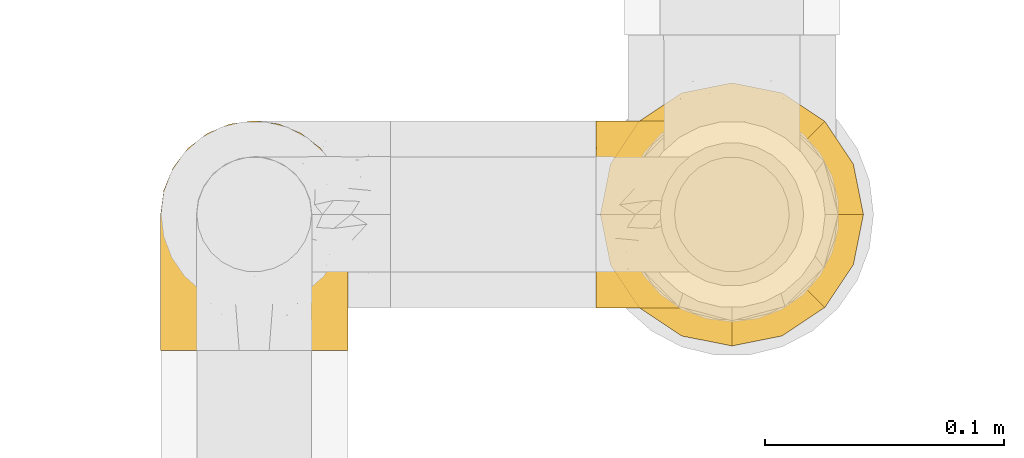
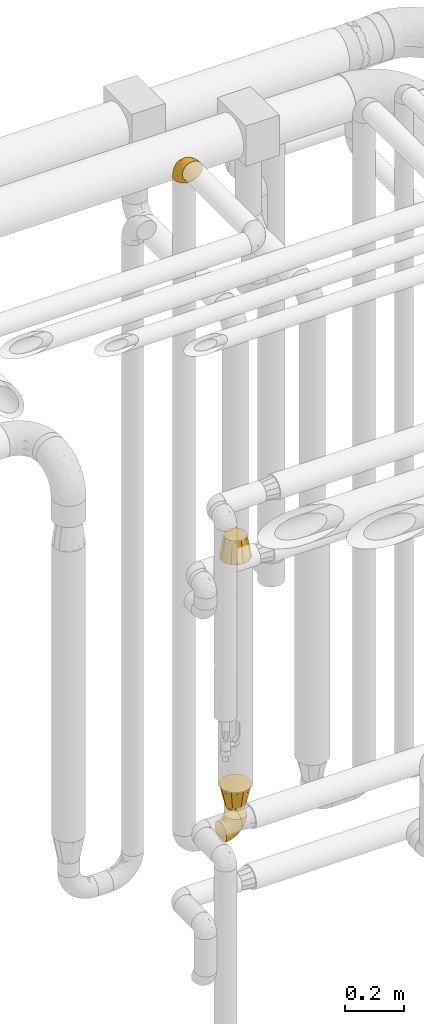
# One storey, part 481 of 827: 4 coverings.
"""IFC2X3 building model written with IfcOpenShell, lengths in millimetres."""

from ifc_helpers import new_model, entity, si_unit, converted_unit, derived_unit, direction, frame, origin, place, context, subcontext, project, spatial, faceted_brep, element, save


model = new_model("IFC2X3")

# Units and contexts
model_context = context("Model", 3, precision=0.01, world=origin(), true_north=direction((6.12303176911189e-17, 1.0)))
body_context = subcontext(model_context, "Body", "Model", "MODEL_VIEW")
ifc_project = project(units=[si_unit("LENGTHUNIT", "METRE", prefix="MILLI"), si_unit("AREAUNIT", "SQUARE_METRE"), si_unit("VOLUMEUNIT", "CUBIC_METRE"), converted_unit("PLANEANGLEUNIT", "DEGREE", entity("IfcRatioMeasure", 0.0174532925199433), si_unit("PLANEANGLEUNIT", "RADIAN"), dimensions=[0, 0, 0, 0, 0, 0, 0]), si_unit("MASSUNIT", "GRAM", prefix="KILO"), derived_unit("MASSDENSITYUNIT", [(si_unit("MASSUNIT", "GRAM", prefix="KILO"), 1), (si_unit("LENGTHUNIT", "METRE"), -3)]), derived_unit("MOMENTOFINERTIAUNIT", [(si_unit("LENGTHUNIT", "METRE"), 4)]), si_unit("TIMEUNIT", "SECOND"), si_unit("FREQUENCYUNIT", "HERTZ"), si_unit("THERMODYNAMICTEMPERATUREUNIT", "DEGREE_CELSIUS"), derived_unit("THERMALTRANSMITTANCEUNIT", [(si_unit("MASSUNIT", "GRAM", prefix="KILO"), 1), (si_unit("THERMODYNAMICTEMPERATUREUNIT", "KELVIN"), -1), (si_unit("TIMEUNIT", "SECOND"), -3)]), derived_unit("VOLUMETRICFLOWRATEUNIT", [(si_unit("LENGTHUNIT", "METRE"), 3), (si_unit("TIMEUNIT", "SECOND"), -1)]), derived_unit("MASSFLOWRATEUNIT", [(si_unit("MASSUNIT", "GRAM", prefix="KILO"), 1), (si_unit("TIMEUNIT", "SECOND"), -1)]), derived_unit("ROTATIONALFREQUENCYUNIT", [(si_unit("TIMEUNIT", "SECOND"), -1)]), si_unit("ELECTRICCURRENTUNIT", "AMPERE"), si_unit("ELECTRICVOLTAGEUNIT", "VOLT"), si_unit("POWERUNIT", "WATT"), si_unit("FORCEUNIT", "NEWTON", prefix="KILO"), si_unit("ILLUMINANCEUNIT", "LUX"), si_unit("LUMINOUSFLUXUNIT", "LUMEN"), si_unit("LUMINOUSINTENSITYUNIT", "CANDELA"), derived_unit("USERDEFINED", [(si_unit("MASSUNIT", "GRAM", prefix="KILO"), -1), (si_unit("LENGTHUNIT", "METRE"), -2), (si_unit("TIMEUNIT", "SECOND"), 3), (si_unit("LUMINOUSFLUXUNIT", "LUMEN"), 1)]), derived_unit("LINEARVELOCITYUNIT", [(si_unit("LENGTHUNIT", "METRE"), 1), (si_unit("TIMEUNIT", "SECOND"), -1)]), si_unit("PRESSUREUNIT", "PASCAL"), derived_unit("USERDEFINED", [(si_unit("LENGTHUNIT", "METRE"), -2), (si_unit("MASSUNIT", "GRAM", prefix="KILO"), 1), (si_unit("TIMEUNIT", "SECOND"), -2)]), derived_unit("LINEARFORCEUNIT", [(si_unit("MASSUNIT", "GRAM", prefix="KILO"), 1), (si_unit("LENGTHUNIT", "METRE"), 1), (si_unit("TIMEUNIT", "SECOND"), -2), (si_unit("LENGTHUNIT", "METRE"), -1)]), derived_unit("PLANARFORCEUNIT", [(si_unit("MASSUNIT", "GRAM", prefix="KILO"), 1), (si_unit("LENGTHUNIT", "METRE"), 1), (si_unit("TIMEUNIT", "SECOND"), -2), (si_unit("LENGTHUNIT", "METRE"), -2)])], contexts=[model_context])

# Site, building, storey
site_placement = place(None, origin())
site = spatial("IfcSite", under=ifc_project, at=site_placement, CompositionType="ELEMENT")
building_placement = place(site_placement, origin())
building = spatial("IfcBuilding", under=site, at=building_placement, CompositionType="ELEMENT")
storey_placement = place(building_placement, frame((0.0, 0.0, 28200.0)))
storey = spatial("IfcBuildingStorey", under=building, at=storey_placement, Name="08", CompositionType="ELEMENT", Elevation=28200.0)

# Coverings
covering_1_placement = place(storey_placement, frame((59239.54, 17459.25, 359.25)))
element("IfcCovering", 1, at=covering_1_placement, inside=storey, Name=":ADSK_", ObjectType=":ADSK_", PredefinedType="INSULATION", context=body_context, shape_type="Brep", body=[
    faceted_brep([(58.6, 1.6, 97.75), (67.31, 2.58, 97.75), (75.59, 5.48, 97.75), (83.01, 10.14, 97.75), (89.21, 16.34, 97.75), (93.87, 23.76, 97.75), (96.76, 32.04, 97.75), (97.75, 40.75, 97.75), (96.76, 49.46, 97.75), (93.87, 57.74, 97.75), (89.2, 65.16, 97.75), (83.0, 71.36, 97.75), (75.58, 76.02, 97.75), (67.3, 78.91, 97.75), (58.6, 79.9, 97.75), (55.4, 79.53, 97.75), (49.88, 78.91, 97.75), (45.74, 77.46, 97.75), (41.6, 76.02, 97.75), (34.18, 71.35, 97.75), (27.98, 65.15, 97.75), (23.32, 57.73, 97.75), (20.43, 49.45, 97.75), (19.45, 40.75, 97.75), (20.43, 32.03, 97.75), (23.33, 23.75, 97.75), (27.99, 16.33, 97.75), (34.19, 10.13, 97.75), (41.61, 5.47, 97.75), (49.89, 2.58, 97.75), (55.4, 1.96, 97.75), (1.6, 68.43, 68.43), (1.6, 74.65, 60.32), (1.6, 78.56, 50.88), (1.6, 79.05, 47.16), (1.6, 79.47, 43.95), (1.6, 79.9, 40.75), (1.6, 78.56, 30.61), (1.6, 74.65, 21.17), (1.6, 68.43, 13.06), (1.6, 60.32, 6.84), (1.6, 50.88, 2.93), (1.6, 40.75, 1.6), (1.6, 30.61, 2.93), (1.6, 21.17, 6.84), (1.6, 13.06, 13.06), (1.6, 6.84, 21.17), (1.6, 2.93, 30.61), (1.6, 1.6, 40.75), (1.6, 2.44, 47.16), (1.6, 2.93, 50.88), (1.6, 6.84, 60.32), (1.6, 13.06, 68.43), (1.6, 21.17, 74.65), (1.6, 30.61, 78.56), (1.6, 40.75, 79.9), (1.6, 50.88, 78.56), (1.6, 60.32, 74.65), (68.75, 40.75, 30.59), (79.38, 40.75, 41.23), (67.95, 27.5, 31.39), (58.11, 40.75, 19.96), (31.31, 40.75, 6.3), (25.48, 34.0, 5.21), (20.85, 40.75, 4.64), (48.28, 29.97, 15.42), (38.29, 19.63, 15.6), (24.38, 27.06, 6.88), (18.7, 18.12, 10.45), (63.4, 2.24, 80.79), (43.9, 4.45, 39.87), (21.15, 5.7, 25.91), (41.26, 8.88, 28.57), (20.94, 2.56, 35.0), (24.69, 11.37, 18.15), (84.73, 14.79, 74.57), (79.29, 8.79, 80.38), (75.09, 11.28, 59.65), (55.53, 2.69, 59.36), (54.26, 1.6, 75.93), (51.17, 1.6, 71.31), (48.08, 1.6, 66.69), (44.99, 1.6, 62.06), (41.9, 1.6, 57.44), (59.1, 7.05, 46.63), (93.12, 29.02, 74.83), (38.11, 2.16, 45.67), (37.28, 1.6, 54.35), (32.65, 1.6, 51.26), (28.03, 1.6, 48.17), (23.41, 1.6, 45.08), (86.26, 32.55, 54.03), (84.36, 22.71, 58.15), (90.84, 21.06, 80.8), (94.7, 40.75, 78.49), (62.67, 19.47, 31.82), (76.37, 23.96, 43.52), (57.88, 1.6, 94.17), (57.17, 1.6, 90.6), (55.75, 1.6, 83.46), (74.1, 17.37, 47.16), (68.09, 5.73, 64.11), (72.38, 4.85, 81.54), (61.34, 12.58, 38.43), (48.69, 14.76, 25.45), (44.71, 40.75, 13.13), (93.04, 40.75, 68.03), (15.88, 1.6, 43.59), (12.31, 1.6, 42.88), (8.74, 1.6, 42.17), (86.21, 40.75, 54.63), (7.55, 17.63, 73.05), (12.14, 12.34, 69.6), (11.84, 2.84, 51.66), (9.55, 8.51, 63.89), (10.89, 5.02, 57.82), (17.57, 4.67, 59.13), (19.53, 2.44, 52.25), (25.5, 2.4, 54.86), (7.5, 30.21, 79.38), (12.73, 30.46, 82.07), (14.22, 40.75, 85.12), (8.19, 40.75, 82.63), (18.5, 31.56, 89.2), (20.38, 22.96, 86.06), (27.96, 11.63, 81.78), (22.53, 16.3, 81.63), (25.05, 10.74, 76.19), (51.05, 2.24, 90.86), (49.37, 2.38, 85.89), (6.49, 23.6, 76.5), (21.79, 25.56, 92.32), (37.29, 3.43, 70.11), (28.49, 6.1, 69.83), (33.82, 3.33, 65.67), (18.63, 14.87, 76.0), (21.37, 8.35, 68.84), (33.2, 10.42, 91.37), (42.33, 3.17, 76.37), (34.77, 7.56, 83.17), (42.81, 4.24, 85.98), (48.27, 2.23, 79.95), (17.49, 21.19, 81.01), (16.71, 40.75, 91.15), (26.81, 15.77, 88.52), (31.65, 6.99, 75.86), (12.9, 20.87, 77.41), (16.9, 7.54, 64.86), (23.37, 4.19, 60.69), (28.95, 3.66, 62.7), (6.49, 57.89, 76.5), (10.35, 63.92, 73.85), (57.88, 79.9, 94.17), (57.17, 79.9, 90.6), (55.75, 79.9, 83.46), (18.5, 49.92, 89.2), (20.37, 58.52, 86.06), (21.79, 55.92, 92.32), (26.8, 65.71, 88.52), (15.88, 79.9, 43.59), (8.74, 79.9, 42.17), (5.17, 79.9, 41.46), (12.14, 69.15, 69.6), (16.74, 73.93, 64.84), (10.0, 72.64, 64.5), (18.6, 78.86, 52.81), (17.57, 76.82, 59.13), (25.3, 79.13, 54.5), (23.41, 79.9, 45.08), (11.84, 78.65, 51.66), (48.27, 79.26, 79.95), (51.17, 79.9, 71.31), (42.31, 78.31, 76.38), (25.03, 70.75, 76.18), (18.73, 66.31, 76.44), (22.25, 65.07, 81.43), (7.5, 51.28, 79.38), (20.15, 71.51, 70.71), (12.73, 51.03, 82.07), (33.19, 71.07, 91.37), (27.5, 69.44, 81.89), (42.79, 77.25, 85.98), (34.75, 73.93, 83.17), (37.29, 78.06, 70.11), (49.36, 79.11, 85.9), (54.26, 79.9, 75.93), (28.95, 77.83, 62.7), (22.98, 77.04, 61.23), (31.63, 74.51, 75.83), (28.42, 75.37, 69.82), (10.01, 76.11, 58.44), (17.3, 59.91, 81.13), (48.08, 79.9, 66.69), (12.9, 60.62, 77.41), (33.78, 78.14, 65.71), (37.28, 79.9, 54.35), (41.9, 79.9, 57.44), (44.99, 79.9, 62.06), (28.03, 79.9, 48.17), (32.65, 79.9, 51.26), (38.11, 79.33, 45.67), (24.7, 70.12, 18.15), (21.15, 75.79, 25.91), (41.27, 72.62, 28.58), (61.33, 68.92, 38.43), (59.09, 74.45, 46.64), (75.08, 70.22, 59.66), (74.09, 64.13, 47.16), (55.53, 78.8, 59.36), (20.94, 78.93, 35.0), (25.48, 47.49, 5.21), (24.38, 54.43, 6.88), (43.89, 77.04, 39.88), (68.08, 75.76, 64.12), (18.7, 63.37, 10.45), (38.29, 61.86, 15.6), (67.95, 54.0, 31.39), (62.66, 62.03, 31.82), (63.4, 79.25, 80.8), (93.12, 52.48, 74.83), (84.73, 66.71, 74.57), (86.25, 48.95, 54.02), (79.28, 72.71, 80.38), (48.28, 51.52, 15.42), (76.37, 57.54, 43.52), (84.35, 58.79, 58.15), (90.83, 60.44, 80.8), (48.7, 66.74, 25.47), (72.37, 76.65, 81.54)], [[[0, 1, 2, 3, 4, 5, 6, 7, 8, 9, 10, 11, 12, 13, 14, 15, 16, 17, 18, 19, 20, 21, 22, 23, 24, 25, 26, 27, 28, 29, 30]], [[31, 32, 33, 34, 35, 36, 37, 38, 39, 40, 41, 42, 43, 44, 45, 46, 47, 48, 49, 50, 51, 52, 53, 54, 55, 56, 57]], [[58, 59, 60, 61]], [[62, 63, 64]], [[65, 66, 67]], [[67, 66, 68]], [[69, 1, 0]], [[70, 71, 72]], [[44, 43, 67]], [[47, 71, 73]], [[45, 74, 46]], [[68, 45, 44]], [[75, 76, 77]], [[76, 3, 2]], [[78, 79, 80, 81, 82, 83]], [[48, 47, 73]], [[70, 72, 84]], [[5, 85, 6]], [[86, 83, 87, 88, 89, 90]], [[91, 85, 92]], [[76, 75, 3]], [[71, 46, 74]], [[85, 5, 93]], [[45, 68, 74]], [[5, 4, 93]], [[85, 94, 6]], [[86, 78, 83]], [[60, 95, 65]], [[96, 95, 60]], [[75, 4, 3]], [[69, 0, 97, 98, 99, 79]], [[75, 77, 100]], [[43, 64, 63]], [[101, 102, 69]], [[101, 76, 102]], [[46, 71, 47]], [[95, 103, 104]], [[92, 85, 93]], [[63, 105, 65]], [[92, 75, 100]], [[91, 106, 85]], [[84, 78, 70]], [[67, 68, 44]], [[65, 67, 63]], [[65, 61, 60]], [[4, 75, 93]], [[92, 93, 75]], [[102, 76, 2]], [[77, 76, 101]], [[84, 77, 101]], [[77, 103, 100]], [[72, 71, 74]], [[70, 86, 73]], [[104, 74, 66]], [[84, 72, 103]], [[70, 73, 71]], [[73, 90, 107, 108, 109, 48]], [[79, 78, 69]], [[101, 69, 78]], [[91, 92, 96]], [[91, 59, 110, 106]], [[2, 1, 102]], [[69, 102, 1]], [[94, 85, 106]], [[94, 7, 6]], [[74, 68, 66]], [[43, 42, 64]], [[43, 63, 67]], [[73, 86, 90]], [[78, 86, 70]], [[95, 100, 103]], [[96, 92, 100]], [[104, 103, 72]], [[65, 95, 66]], [[74, 104, 72]], [[66, 95, 104]], [[95, 96, 100]], [[91, 96, 60]], [[77, 84, 103]], [[78, 84, 101]], [[60, 59, 91]], [[105, 63, 62]], [[105, 61, 65]], [[111, 52, 112]], [[107, 90, 113]], [[114, 115, 116]], [[50, 107, 113]], [[117, 118, 116]], [[54, 119, 55]], [[97, 0, 30, 29, 98]], [[113, 115, 51]], [[120, 121, 122]], [[123, 120, 124]], [[125, 126, 127]], [[128, 28, 129]], [[130, 54, 53]], [[25, 24, 131]], [[132, 133, 134]], [[135, 112, 136]], [[137, 27, 26]], [[121, 120, 123]], [[138, 139, 132]], [[129, 140, 141]], [[135, 126, 142]], [[27, 140, 28]], [[27, 137, 140]], [[49, 48, 109, 108, 107, 50]], [[23, 143, 121, 123]], [[25, 131, 144]], [[26, 25, 144]], [[128, 98, 29]], [[125, 127, 145]], [[146, 130, 111]], [[137, 144, 139]], [[139, 138, 140]], [[116, 147, 114]], [[123, 124, 131]], [[116, 118, 148]], [[134, 83, 82]], [[129, 79, 99]], [[54, 130, 119]], [[141, 79, 129]], [[122, 55, 119]], [[120, 146, 142]], [[117, 113, 90]], [[50, 113, 51]], [[127, 133, 145]], [[147, 136, 112]], [[136, 133, 127]], [[24, 23, 123]], [[118, 117, 89]], [[149, 87, 134]], [[144, 131, 124]], [[24, 123, 131]], [[128, 129, 99]], [[28, 140, 129]], [[144, 137, 26]], [[140, 137, 139]], [[81, 138, 132]], [[138, 80, 141]], [[89, 88, 87, 118]], [[115, 117, 116]], [[140, 138, 141]], [[148, 118, 149]], [[136, 148, 149]], [[147, 116, 148]], [[133, 136, 149]], [[127, 126, 135]], [[136, 147, 148]], [[114, 112, 52]], [[112, 114, 147]], [[51, 114, 52]], [[51, 115, 114]], [[117, 115, 113]], [[117, 90, 89]], [[134, 133, 149]], [[145, 133, 132]], [[132, 139, 145]], [[125, 139, 144]], [[139, 125, 145]], [[126, 144, 124]], [[144, 126, 125]], [[142, 126, 124]], [[120, 142, 124]], [[142, 146, 135]], [[112, 135, 146]], [[136, 127, 135]], [[118, 87, 149]], [[82, 81, 132]], [[111, 130, 53]], [[119, 146, 120]], [[146, 119, 130]], [[122, 119, 120]], [[52, 111, 53]], [[146, 111, 112]], [[134, 82, 132]], [[83, 134, 87]], [[98, 128, 99]], [[80, 138, 81]], [[80, 79, 141]], [[28, 128, 29]], [[150, 151, 57]], [[15, 14, 152, 153, 154, 16]], [[121, 143, 23, 155]], [[150, 57, 56]], [[156, 157, 158]], [[35, 34, 33, 159, 160, 161, 36]], [[162, 31, 57]], [[163, 164, 162]], [[165, 166, 167]], [[155, 23, 22]], [[168, 159, 169]], [[170, 171, 172]], [[173, 174, 175]], [[55, 122, 176]], [[177, 174, 173]], [[22, 157, 155]], [[178, 121, 155]], [[169, 33, 32]], [[20, 19, 179]], [[21, 20, 158]], [[158, 180, 175]], [[181, 182, 179]], [[172, 183, 182]], [[122, 121, 178]], [[181, 19, 18]], [[184, 185, 170]], [[17, 154, 184]], [[186, 187, 177]], [[187, 186, 167]], [[179, 158, 20]], [[21, 157, 22]], [[175, 180, 173]], [[188, 189, 173]], [[164, 166, 190]], [[185, 184, 154]], [[181, 172, 182]], [[156, 191, 178]], [[192, 183, 172]], [[178, 176, 122]], [[193, 150, 176]], [[33, 169, 159]], [[190, 169, 32]], [[189, 194, 186]], [[180, 188, 173]], [[167, 166, 187]], [[166, 164, 163]], [[195, 194, 196]], [[158, 157, 21]], [[155, 157, 156]], [[178, 155, 156]], [[181, 18, 184]], [[17, 16, 154]], [[181, 179, 19]], [[158, 179, 182]], [[170, 181, 184]], [[196, 194, 197]], [[31, 190, 32]], [[165, 190, 166]], [[190, 31, 164]], [[31, 162, 164]], [[177, 163, 162]], [[187, 166, 163]], [[151, 174, 177]], [[177, 173, 189]], [[177, 187, 163]], [[195, 167, 186]], [[165, 198, 168]], [[165, 168, 169]], [[167, 198, 165]], [[190, 165, 169]], [[167, 195, 199, 198]], [[151, 177, 162]], [[175, 191, 156]], [[191, 174, 193]], [[158, 175, 156]], [[174, 191, 175]], [[178, 191, 193]], [[158, 182, 180]], [[188, 182, 183]], [[182, 188, 180]], [[183, 194, 189]], [[183, 189, 188]], [[177, 189, 186]], [[194, 183, 197]], [[176, 150, 56]], [[151, 150, 193]], [[176, 56, 55]], [[193, 176, 178]], [[174, 151, 193]], [[57, 151, 162]], [[183, 192, 197]], [[194, 195, 186]], [[171, 192, 172]], [[172, 181, 170]], [[170, 185, 171]], [[184, 18, 17]], [[200, 168, 198, 199, 195, 196]], [[201, 202, 203]], [[204, 203, 205]], [[204, 206, 207]], [[208, 196, 197, 192, 171, 185]], [[209, 36, 161, 160, 159, 168]], [[202, 38, 37]], [[201, 38, 202]], [[210, 41, 211]], [[200, 208, 212]], [[205, 208, 213]], [[214, 211, 40]], [[40, 211, 41]], [[214, 201, 215]], [[58, 61, 216, 59]], [[201, 39, 38]], [[207, 217, 204]], [[213, 208, 218]], [[218, 185, 154, 153, 152, 14]], [[14, 13, 218]], [[9, 8, 219]], [[10, 220, 11]], [[221, 106, 110, 59]], [[219, 8, 94]], [[220, 222, 11]], [[223, 211, 215]], [[221, 216, 224]], [[225, 219, 221]], [[10, 9, 226]], [[213, 222, 206]], [[226, 9, 219]], [[106, 219, 94]], [[212, 202, 209]], [[201, 203, 227]], [[226, 225, 220]], [[207, 206, 220]], [[214, 40, 39]], [[11, 222, 12]], [[12, 222, 228]], [[41, 210, 64]], [[223, 105, 210]], [[223, 215, 217]], [[105, 62, 210]], [[206, 222, 220]], [[228, 222, 213]], [[207, 220, 225]], [[205, 206, 204]], [[225, 226, 219]], [[220, 10, 226]], [[209, 202, 37]], [[203, 202, 212]], [[205, 203, 212]], [[204, 217, 227]], [[36, 209, 37]], [[209, 168, 200]], [[218, 13, 228]], [[208, 185, 218]], [[106, 221, 219]], [[221, 59, 216]], [[218, 228, 213]], [[13, 12, 228]], [[8, 7, 94]], [[201, 214, 39]], [[211, 214, 215]], [[64, 210, 62]], [[64, 42, 41]], [[223, 210, 211]], [[208, 200, 196]], [[209, 200, 212]], [[225, 224, 207]], [[207, 224, 217]], [[223, 217, 216]], [[204, 227, 203]], [[217, 215, 227]], [[201, 227, 215]], [[221, 224, 225]], [[217, 224, 216]], [[208, 205, 212]], [[206, 205, 213]], [[216, 61, 223]], [[223, 61, 105]]]),
])
covering_2_placement = place(storey_placement, frame((59057.39, 17441.4, 3141.4)))
element("IfcCovering", 2, at=covering_2_placement, inside=storey, Name=":ADSK_", ObjectType=":ADSK_", PredefinedType="INSULATION", context=body_context, shape_type="Brep", body=[
    faceted_brep([(79.9, 1.6, 58.6), (78.91, 1.6, 67.31), (76.02, 1.6, 75.59), (71.35, 1.6, 83.01), (65.15, 1.6, 89.21), (57.73, 1.6, 93.87), (49.45, 1.6, 96.76), (40.75, 1.6, 97.75), (32.03, 1.6, 96.76), (23.75, 1.6, 93.87), (16.33, 1.6, 89.2), (10.13, 1.6, 83.0), (5.47, 1.6, 75.58), (2.58, 1.6, 67.3), (1.6, 1.6, 58.6), (1.96, 1.6, 55.4), (2.58, 1.6, 49.88), (4.03, 1.6, 45.74), (5.48, 1.6, 41.6), (10.14, 1.6, 34.18), (16.34, 1.6, 27.98), (23.76, 1.6, 23.32), (32.04, 1.6, 20.43), (40.75, 1.6, 19.45), (49.46, 1.6, 20.43), (57.74, 1.6, 23.33), (65.16, 1.6, 27.99), (71.36, 1.6, 34.19), (76.02, 1.6, 41.61), (78.91, 1.6, 49.89), (79.54, 1.6, 55.4), (13.06, 30.91, 1.6), (6.84, 39.02, 1.6), (2.93, 48.46, 1.6), (2.44, 52.18, 1.6), (2.02, 55.39, 1.6), (1.6, 58.6, 1.6), (2.93, 68.73, 1.6), (6.84, 78.17, 1.6), (13.06, 86.28, 1.6), (21.17, 92.5, 1.6), (30.61, 96.41, 1.6), (40.75, 97.75, 1.6), (50.88, 96.41, 1.6), (60.32, 92.5, 1.6), (68.43, 86.28, 1.6), (74.65, 78.17, 1.6), (78.56, 68.73, 1.6), (79.9, 58.6, 1.6), (79.05, 52.18, 1.6), (78.56, 48.46, 1.6), (74.65, 39.02, 1.6), (68.43, 30.91, 1.6), (60.32, 24.69, 1.6), (50.88, 20.78, 1.6), (40.75, 19.45, 1.6), (30.61, 20.78, 1.6), (21.17, 24.69, 1.6), (40.75, 68.75, 68.75), (40.75, 58.11, 79.38), (53.99, 67.95, 67.95), (40.75, 79.38, 58.11), (40.75, 93.04, 31.31), (47.49, 94.13, 25.48), (40.75, 94.7, 20.85), (51.52, 83.92, 48.28), (61.86, 83.74, 38.29), (54.43, 92.46, 24.38), (63.37, 88.89, 18.7), (79.25, 18.55, 63.4), (77.04, 59.47, 43.9), (75.79, 73.43, 21.15), (72.61, 70.77, 41.26), (78.93, 64.34, 20.94), (70.12, 81.19, 24.69), (66.7, 24.77, 84.73), (72.7, 18.96, 79.29), (70.21, 39.69, 75.09), (78.8, 39.98, 55.53), (79.9, 23.41, 54.26), (79.9, 28.03, 51.17), (79.9, 32.65, 48.08), (79.9, 37.28, 44.99), (79.9, 41.9, 41.9), (74.44, 52.71, 59.1), (52.47, 24.51, 93.12), (79.33, 53.67, 38.11), (79.9, 44.99, 37.28), (79.9, 48.08, 32.65), (79.9, 51.17, 28.03), (79.9, 54.26, 23.41), (48.94, 45.31, 86.26), (58.78, 41.19, 84.36), (60.43, 18.54, 90.84), (40.75, 20.85, 94.7), (62.02, 67.52, 62.67), (57.53, 55.82, 76.37), (79.9, 5.17, 57.88), (79.9, 8.74, 57.17), (79.9, 15.88, 55.75), (64.12, 52.18, 74.1), (75.76, 35.23, 68.09), (76.65, 17.8, 72.38), (68.92, 60.91, 61.34), (66.73, 73.89, 48.69), (40.75, 86.21, 44.71), (40.75, 31.31, 93.04), (79.9, 55.75, 15.88), (79.9, 56.46, 12.31), (79.9, 57.17, 8.74), (40.75, 44.71, 86.21), (63.86, 26.29, 7.55), (69.15, 29.74, 12.14), (78.65, 47.68, 11.84), (72.98, 35.46, 9.55), (76.47, 41.52, 10.89), (76.82, 40.21, 17.57), (79.05, 47.09, 19.53), (79.09, 44.48, 25.5), (51.28, 19.96, 7.5), (51.03, 17.27, 12.73), (40.75, 14.22, 14.22), (40.75, 16.71, 8.19), (49.93, 10.14, 18.5), (58.53, 13.28, 20.38), (69.86, 17.56, 27.96), (65.19, 17.71, 22.53), (70.75, 23.15, 25.05), (79.25, 8.48, 51.05), (79.11, 13.45, 49.37), (57.89, 22.84, 6.49), (55.93, 7.02, 21.79), (78.06, 29.23, 37.29), (75.39, 29.51, 28.49), (78.16, 33.67, 33.82), (66.62, 23.34, 18.63), (73.14, 30.5, 21.37), (71.07, 7.97, 33.2), (78.32, 22.97, 42.33), (73.93, 16.17, 34.77), (77.25, 13.36, 42.81), (79.26, 19.39, 48.27), (60.3, 18.33, 17.49), (40.75, 8.19, 16.71), (65.72, 10.82, 26.81), (74.5, 23.48, 31.65), (60.62, 21.93, 12.9), (73.96, 34.48, 16.9), (77.3, 38.65, 23.37), (77.83, 36.64, 28.95), (23.6, 22.84, 6.49), (17.57, 25.49, 10.35), (1.6, 5.17, 57.88), (1.6, 8.74, 57.17), (1.6, 15.88, 55.75), (31.57, 10.14, 18.5), (22.97, 13.28, 20.37), (25.57, 7.02, 21.79), (15.78, 10.82, 26.8), (1.6, 55.75, 15.88), (1.6, 57.17, 8.74), (1.6, 57.88, 5.17), (12.34, 29.74, 12.14), (7.57, 34.5, 16.74), (8.85, 34.84, 10.0), (2.63, 46.53, 18.6), (4.67, 40.21, 17.57), (2.36, 44.84, 25.3), (1.6, 54.26, 23.41), (2.84, 47.68, 11.84), (2.24, 19.39, 48.27), (1.6, 28.03, 51.17), (3.18, 22.96, 42.31), (10.74, 23.16, 25.03), (15.18, 22.9, 18.73), (16.42, 17.91, 22.25), (30.21, 19.96, 7.5), (9.98, 28.63, 20.15), (30.46, 17.27, 12.73), (10.43, 7.97, 33.19), (12.05, 17.45, 27.5), (4.24, 13.36, 42.79), (7.56, 16.17, 34.75), (3.43, 29.23, 37.29), (2.38, 13.44, 49.36), (1.6, 23.41, 54.26), (3.66, 36.64, 28.95), (4.45, 38.11, 22.98), (6.98, 23.51, 31.63), (6.12, 29.52, 28.42), (5.38, 40.9, 10.01), (21.58, 18.21, 17.3), (3.35, 33.63, 33.78), (1.6, 37.28, 44.99), (20.87, 21.93, 12.9), (1.6, 44.99, 37.28), (1.6, 41.9, 41.9), (1.6, 51.17, 28.03), (1.6, 48.08, 32.65), (1.6, 32.65, 48.08), (2.16, 53.67, 38.11), (11.37, 81.19, 24.7), (5.7, 73.43, 21.15), (8.88, 70.76, 41.27), (12.57, 60.91, 61.33), (7.04, 52.7, 59.09), (11.27, 39.68, 75.08), (17.36, 52.18, 74.09), (2.69, 39.98, 55.53), (2.56, 64.34, 20.94), (34.0, 94.13, 25.48), (27.06, 92.46, 24.38), (4.45, 59.46, 43.89), (5.73, 35.22, 68.08), (18.12, 88.89, 18.7), (19.63, 83.74, 38.29), (27.49, 67.95, 67.95), (19.46, 67.52, 62.66), (2.24, 18.55, 63.4), (29.01, 24.51, 93.12), (14.78, 24.77, 84.73), (32.55, 45.32, 86.25), (8.78, 18.96, 79.28), (29.98, 83.92, 48.28), (23.95, 55.82, 76.37), (22.7, 41.19, 84.35), (21.05, 18.54, 90.83), (14.75, 73.87, 48.7), (4.84, 17.8, 72.37)], [[[0, 1, 2, 3, 4, 5, 6, 7, 8, 9, 10, 11, 12, 13, 14, 15, 16, 17, 18, 19, 20, 21, 22, 23, 24, 25, 26, 27, 28, 29, 30]], [[31, 32, 33, 34, 35, 36, 37, 38, 39, 40, 41, 42, 43, 44, 45, 46, 47, 48, 49, 50, 51, 52, 53, 54, 55, 56, 57]], [[58, 59, 60, 61]], [[62, 63, 64]], [[65, 66, 67]], [[67, 66, 68]], [[69, 1, 0]], [[70, 71, 72]], [[44, 43, 67]], [[47, 71, 73]], [[45, 74, 46]], [[68, 45, 44]], [[75, 76, 77]], [[76, 3, 2]], [[78, 79, 80, 81, 82, 83]], [[48, 47, 73]], [[70, 72, 84]], [[5, 85, 6]], [[86, 83, 87, 88, 89, 90]], [[91, 85, 92]], [[76, 75, 3]], [[71, 46, 74]], [[85, 5, 93]], [[45, 68, 74]], [[5, 4, 93]], [[85, 94, 6]], [[86, 78, 83]], [[60, 95, 65]], [[96, 95, 60]], [[75, 4, 3]], [[69, 0, 97, 98, 99, 79]], [[75, 77, 100]], [[43, 64, 63]], [[101, 102, 69]], [[101, 76, 102]], [[46, 71, 47]], [[95, 103, 104]], [[92, 85, 93]], [[63, 105, 65]], [[92, 75, 100]], [[91, 106, 85]], [[84, 78, 70]], [[67, 68, 44]], [[65, 67, 63]], [[65, 61, 60]], [[4, 75, 93]], [[92, 93, 75]], [[102, 76, 2]], [[77, 76, 101]], [[84, 77, 101]], [[77, 103, 100]], [[72, 71, 74]], [[70, 86, 73]], [[104, 74, 66]], [[84, 72, 103]], [[70, 73, 71]], [[73, 90, 107, 108, 109, 48]], [[79, 78, 69]], [[101, 69, 78]], [[91, 92, 96]], [[91, 59, 110, 106]], [[2, 1, 102]], [[69, 102, 1]], [[94, 85, 106]], [[94, 7, 6]], [[74, 68, 66]], [[43, 42, 64]], [[43, 63, 67]], [[73, 86, 90]], [[78, 86, 70]], [[95, 100, 103]], [[96, 92, 100]], [[104, 103, 72]], [[65, 95, 66]], [[74, 104, 72]], [[66, 95, 104]], [[95, 96, 100]], [[91, 96, 60]], [[77, 84, 103]], [[78, 84, 101]], [[60, 59, 91]], [[105, 63, 62]], [[105, 61, 65]], [[111, 52, 112]], [[107, 90, 113]], [[114, 115, 116]], [[50, 107, 113]], [[117, 118, 116]], [[54, 119, 55]], [[97, 0, 30, 29, 98]], [[113, 115, 51]], [[120, 121, 122]], [[123, 120, 124]], [[125, 126, 127]], [[128, 28, 129]], [[130, 54, 53]], [[25, 24, 131]], [[132, 133, 134]], [[135, 112, 136]], [[137, 27, 26]], [[121, 120, 123]], [[138, 139, 132]], [[129, 140, 141]], [[135, 126, 142]], [[27, 140, 28]], [[27, 137, 140]], [[49, 48, 109, 108, 107, 50]], [[23, 143, 121, 123]], [[25, 131, 144]], [[26, 25, 144]], [[128, 98, 29]], [[125, 127, 145]], [[146, 130, 111]], [[137, 144, 139]], [[139, 138, 140]], [[116, 147, 114]], [[123, 124, 131]], [[116, 118, 148]], [[134, 83, 82]], [[129, 79, 99]], [[54, 130, 119]], [[141, 79, 129]], [[122, 55, 119]], [[120, 146, 142]], [[117, 113, 90]], [[50, 113, 51]], [[127, 133, 145]], [[147, 136, 112]], [[136, 133, 127]], [[24, 23, 123]], [[118, 117, 89]], [[149, 87, 134]], [[144, 131, 124]], [[24, 123, 131]], [[128, 129, 99]], [[28, 140, 129]], [[144, 137, 26]], [[140, 137, 139]], [[81, 138, 132]], [[138, 80, 141]], [[89, 88, 87, 118]], [[115, 117, 116]], [[140, 138, 141]], [[148, 118, 149]], [[136, 148, 149]], [[147, 116, 148]], [[133, 136, 149]], [[127, 126, 135]], [[136, 147, 148]], [[114, 112, 52]], [[112, 114, 147]], [[51, 114, 52]], [[51, 115, 114]], [[117, 115, 113]], [[117, 90, 89]], [[134, 133, 149]], [[145, 133, 132]], [[132, 139, 145]], [[125, 139, 144]], [[139, 125, 145]], [[126, 144, 124]], [[144, 126, 125]], [[142, 126, 124]], [[120, 142, 124]], [[142, 146, 135]], [[112, 135, 146]], [[136, 127, 135]], [[118, 87, 149]], [[82, 81, 132]], [[111, 130, 53]], [[119, 146, 120]], [[146, 119, 130]], [[122, 119, 120]], [[52, 111, 53]], [[146, 111, 112]], [[134, 82, 132]], [[83, 134, 87]], [[98, 128, 99]], [[80, 138, 81]], [[80, 79, 141]], [[28, 128, 29]], [[150, 151, 57]], [[15, 14, 152, 153, 154, 16]], [[121, 143, 23, 155]], [[150, 57, 56]], [[156, 157, 158]], [[35, 34, 33, 159, 160, 161, 36]], [[162, 31, 57]], [[163, 164, 162]], [[165, 166, 167]], [[155, 23, 22]], [[168, 159, 169]], [[170, 171, 172]], [[173, 174, 175]], [[55, 122, 176]], [[177, 174, 173]], [[22, 157, 155]], [[178, 121, 155]], [[169, 33, 32]], [[20, 19, 179]], [[21, 20, 158]], [[158, 180, 175]], [[181, 182, 179]], [[172, 183, 182]], [[122, 121, 178]], [[181, 19, 18]], [[184, 185, 170]], [[17, 154, 184]], [[186, 187, 177]], [[187, 186, 167]], [[179, 158, 20]], [[21, 157, 22]], [[175, 180, 173]], [[188, 189, 173]], [[164, 166, 190]], [[185, 184, 154]], [[181, 172, 182]], [[156, 191, 178]], [[192, 183, 193]], [[178, 176, 122]], [[194, 150, 176]], [[33, 169, 159]], [[190, 169, 32]], [[189, 192, 186]], [[180, 188, 173]], [[167, 166, 187]], [[166, 164, 163]], [[195, 192, 196]], [[158, 157, 21]], [[155, 157, 156]], [[178, 155, 156]], [[181, 18, 184]], [[17, 16, 154]], [[181, 179, 19]], [[158, 179, 182]], [[170, 181, 184]], [[192, 195, 186]], [[31, 190, 32]], [[165, 190, 166]], [[190, 31, 164]], [[31, 162, 164]], [[177, 163, 162]], [[187, 166, 163]], [[151, 174, 177]], [[177, 173, 189]], [[177, 187, 163]], [[195, 167, 186]], [[165, 197, 168]], [[165, 168, 169]], [[167, 197, 165]], [[190, 165, 169]], [[167, 195, 198, 197]], [[151, 177, 162]], [[175, 191, 156]], [[191, 174, 194]], [[158, 175, 156]], [[174, 191, 175]], [[178, 191, 194]], [[158, 182, 180]], [[188, 182, 183]], [[182, 188, 180]], [[183, 192, 189]], [[183, 189, 188]], [[177, 189, 186]], [[183, 199, 193]], [[176, 150, 56]], [[151, 150, 194]], [[176, 56, 55]], [[194, 176, 178]], [[174, 151, 194]], [[57, 151, 162]], [[199, 183, 172]], [[196, 192, 193]], [[171, 199, 172]], [[172, 181, 170]], [[170, 185, 171]], [[184, 18, 17]], [[200, 168, 197, 198, 195, 196]], [[201, 202, 203]], [[204, 203, 205]], [[204, 206, 207]], [[208, 196, 193, 199, 171, 185]], [[209, 36, 161, 160, 159, 168]], [[202, 38, 37]], [[201, 38, 202]], [[210, 41, 211]], [[200, 208, 212]], [[205, 208, 213]], [[214, 211, 40]], [[40, 211, 41]], [[214, 201, 215]], [[58, 61, 216, 59]], [[201, 39, 38]], [[207, 217, 204]], [[213, 208, 218]], [[218, 185, 154, 153, 152, 14]], [[14, 13, 218]], [[9, 8, 219]], [[10, 220, 11]], [[221, 106, 110, 59]], [[219, 8, 94]], [[220, 222, 11]], [[223, 211, 215]], [[221, 216, 224]], [[225, 219, 221]], [[10, 9, 226]], [[213, 222, 206]], [[226, 9, 219]], [[106, 219, 94]], [[212, 202, 209]], [[201, 203, 227]], [[226, 225, 220]], [[207, 206, 220]], [[214, 40, 39]], [[11, 222, 12]], [[12, 222, 228]], [[41, 210, 64]], [[223, 105, 210]], [[223, 215, 217]], [[105, 62, 210]], [[206, 222, 220]], [[228, 222, 213]], [[207, 220, 225]], [[205, 206, 204]], [[225, 226, 219]], [[220, 10, 226]], [[209, 202, 37]], [[203, 202, 212]], [[205, 203, 212]], [[204, 217, 227]], [[36, 209, 37]], [[209, 168, 200]], [[218, 13, 228]], [[208, 185, 218]], [[106, 221, 219]], [[221, 59, 216]], [[218, 228, 213]], [[13, 12, 228]], [[8, 7, 94]], [[201, 214, 39]], [[211, 214, 215]], [[64, 210, 62]], [[64, 42, 41]], [[223, 210, 211]], [[208, 200, 196]], [[209, 200, 212]], [[225, 224, 207]], [[207, 224, 217]], [[223, 217, 216]], [[204, 227, 203]], [[217, 215, 227]], [[201, 227, 215]], [[221, 224, 225]], [[217, 224, 216]], [[208, 205, 212]], [[206, 205, 213]], [[216, 61, 223]], [[223, 61, 105]]]),
])
covering_3_placement = place(storey_placement, frame((59241.3, 17443.4, 1513.24)))
element("IfcCovering", 3, at=covering_3_placement, inside=storey, Name=":ADSK_", ObjectType=":ADSK_", PredefinedType="INSULATION", context=body_context, shape_type="Brep", body=[
    faceted_brep([(77.64, 5.78, 0.0), (67.12, 3.69, 0.0), (56.6, 1.6, 0.0), (46.07, 3.69, 0.0), (35.55, 5.78, 0.0), (26.63, 11.74, 0.0), (17.7, 17.7, 0.0), (11.74, 26.63, 0.0), (5.78, 35.55, 0.0), (3.69, 46.07, 0.0), (1.6, 56.6, 0.0), (3.69, 67.12, 0.0), (5.78, 77.64, 0.0), (11.74, 86.56, 0.0), (17.7, 95.49, 0.0), (26.63, 101.45, 0.0), (35.55, 107.41, 0.0), (46.07, 109.5, 0.0), (56.6, 111.6, 0.0), (67.12, 109.5, 0.0), (77.64, 107.41, 0.0), (86.56, 101.45, 0.0), (95.49, 95.49, 0.0), (101.45, 86.56, 0.0), (107.41, 77.64, 0.0), (109.5, 67.12, 0.0), (111.6, 56.6, 0.0), (109.5, 46.07, 0.0), (107.41, 35.55, 0.0), (101.45, 26.63, 0.0), (95.49, 17.7, 0.0), (86.56, 11.74, 0.0), (91.24, 76.6, 89.0), (83.92, 83.92, 89.0), (76.6, 91.24, 89.0), (66.6, 93.92, 89.0), (56.6, 96.6, 89.0), (46.6, 93.92, 89.0), (36.6, 91.24, 89.0), (29.27, 83.92, 89.0), (21.95, 76.6, 89.0), (19.27, 66.6, 89.0), (16.6, 56.6, 89.0), (19.27, 46.6, 89.0), (21.95, 36.6, 89.0), (29.27, 29.27, 89.0), (36.6, 21.95, 89.0), (46.6, 19.27, 89.0), (56.6, 16.6, 89.0), (66.6, 19.27, 89.0), (76.6, 21.95, 89.0), (83.92, 29.27, 89.0), (91.24, 36.6, 89.0), (93.92, 46.6, 89.0), (96.6, 56.6, 89.0), (93.92, 66.6, 89.0)], [[[0, 1, 2, 3, 4, 5, 6, 7, 8, 9, 10, 11, 12, 13, 14, 15, 16, 17, 18, 19, 20, 21, 22, 23, 24, 25, 26, 27, 28, 29, 30, 31]], [[32, 33, 34, 35, 36, 37, 38, 39, 40, 41, 42, 43, 44, 45, 46, 47, 48, 49, 50, 51, 52, 53, 54, 55]], [[3, 2, 48]], [[44, 7, 45]], [[45, 5, 46]], [[48, 47, 3]], [[6, 45, 7]], [[44, 8, 7]], [[5, 45, 6]], [[42, 9, 43]], [[5, 4, 46]], [[47, 46, 4]], [[9, 42, 10]], [[8, 44, 43]], [[9, 8, 43]], [[47, 4, 3]], [[11, 10, 42]], [[38, 15, 39]], [[39, 13, 40]], [[42, 41, 11]], [[14, 39, 15]], [[38, 16, 15]], [[13, 39, 14]], [[36, 17, 37]], [[13, 12, 40]], [[41, 40, 12]], [[17, 36, 18]], [[16, 38, 37]], [[17, 16, 37]], [[41, 12, 11]], [[19, 18, 36]], [[32, 23, 33]], [[33, 21, 34]], [[36, 35, 19]], [[22, 33, 23]], [[32, 24, 23]], [[21, 33, 22]], [[54, 25, 55]], [[21, 20, 34]], [[35, 34, 20]], [[25, 54, 26]], [[24, 32, 55]], [[25, 24, 55]], [[35, 20, 19]], [[27, 26, 54]], [[50, 31, 51]], [[51, 29, 52]], [[54, 53, 27]], [[30, 51, 31]], [[50, 0, 31]], [[29, 51, 30]], [[48, 1, 49]], [[29, 28, 52]], [[53, 52, 28]], [[1, 48, 2]], [[0, 50, 49]], [[1, 0, 49]], [[53, 28, 27]]]),
])
covering_4_placement = place(storey_placement, frame((59241.3, 17443.4, 490.0)))
element("IfcCovering", 4, at=covering_4_placement, inside=storey, Name=":ADSK_", ObjectType=":ADSK_", PredefinedType="INSULATION", context=body_context, shape_type="Brep", body=[
    faceted_brep([(91.6, 56.6, 0.0), (89.25, 47.85, 0.0), (86.91, 39.1, 0.0), (80.5, 32.69, 0.0), (74.1, 26.28, 0.0), (65.35, 23.94, 0.0), (56.6, 21.6, 0.0), (47.85, 23.94, 0.0), (39.1, 26.28, 0.0), (32.69, 32.69, 0.0), (26.28, 39.1, 0.0), (23.94, 47.85, 0.0), (21.6, 56.6, 0.0), (23.94, 65.35, 0.0), (26.28, 74.1, 0.0), (32.69, 80.5, 0.0), (39.1, 86.91, 0.0), (47.85, 89.25, 0.0), (56.6, 91.6, 0.0), (65.35, 89.25, 0.0), (74.1, 86.91, 0.0), (80.5, 80.5, 0.0), (86.91, 74.1, 0.0), (89.25, 65.35, 0.0), (1.6, 56.6, 89.0), (3.69, 46.07, 89.0), (5.78, 35.55, 89.0), (11.74, 26.63, 89.0), (17.7, 17.7, 89.0), (26.63, 11.74, 89.0), (35.55, 5.78, 89.0), (46.07, 3.69, 89.0), (56.6, 1.6, 89.0), (67.12, 3.69, 89.0), (77.64, 5.78, 89.0), (86.56, 11.74, 89.0), (95.49, 17.7, 89.0), (101.45, 26.63, 89.0), (107.41, 35.55, 89.0), (109.5, 46.07, 89.0), (111.6, 56.6, 89.0), (109.5, 67.12, 89.0), (107.41, 77.64, 89.0), (101.45, 86.56, 89.0), (95.49, 95.49, 89.0), (86.56, 101.45, 89.0), (77.64, 107.41, 89.0), (67.12, 109.5, 89.0), (56.6, 111.6, 89.0), (46.07, 109.5, 89.0), (35.55, 107.41, 89.0), (26.63, 101.45, 89.0), (17.7, 95.49, 89.0), (11.74, 86.56, 89.0), (5.78, 77.64, 89.0), (3.69, 67.12, 89.0)], [[[0, 1, 2, 3, 4, 5, 6, 7, 8, 9, 10, 11, 12, 13, 14, 15, 16, 17, 18, 19, 20, 21, 22, 23]], [[24, 25, 26, 27, 28, 29, 30, 31, 32, 33, 34, 35, 36, 37, 38, 39, 40, 41, 42, 43, 44, 45, 46, 47, 48, 49, 50, 51, 52, 53, 54, 55]], [[33, 32, 6]], [[2, 38, 37]], [[35, 34, 4]], [[35, 4, 3]], [[2, 37, 3]], [[35, 3, 36]], [[39, 38, 1]], [[6, 5, 33]], [[37, 36, 3]], [[0, 39, 1]], [[5, 4, 34]], [[39, 0, 40]], [[38, 2, 1]], [[5, 34, 33]], [[25, 24, 12]], [[8, 30, 29]], [[27, 26, 10]], [[27, 10, 9]], [[8, 29, 9]], [[27, 9, 28]], [[31, 30, 7]], [[12, 11, 25]], [[29, 28, 9]], [[6, 31, 7]], [[11, 10, 26]], [[31, 6, 32]], [[30, 8, 7]], [[11, 26, 25]], [[49, 48, 18]], [[14, 54, 53]], [[51, 50, 16]], [[51, 16, 15]], [[14, 53, 15]], [[51, 15, 52]], [[55, 54, 13]], [[18, 17, 49]], [[53, 52, 15]], [[12, 55, 13]], [[17, 16, 50]], [[55, 12, 24]], [[54, 14, 13]], [[17, 50, 49]], [[41, 40, 0]], [[20, 46, 45]], [[43, 42, 22]], [[43, 22, 21]], [[20, 45, 21]], [[43, 21, 44]], [[47, 46, 19]], [[0, 23, 41]], [[45, 44, 21]], [[18, 47, 19]], [[23, 22, 42]], [[47, 18, 48]], [[46, 20, 19]], [[23, 42, 41]]]),
])

save(model, "model.ifc")
